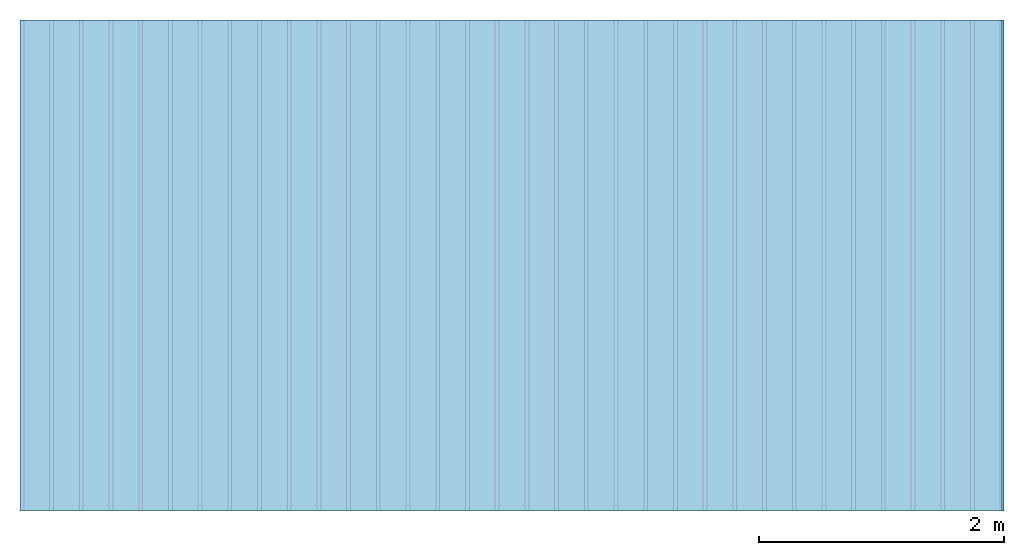
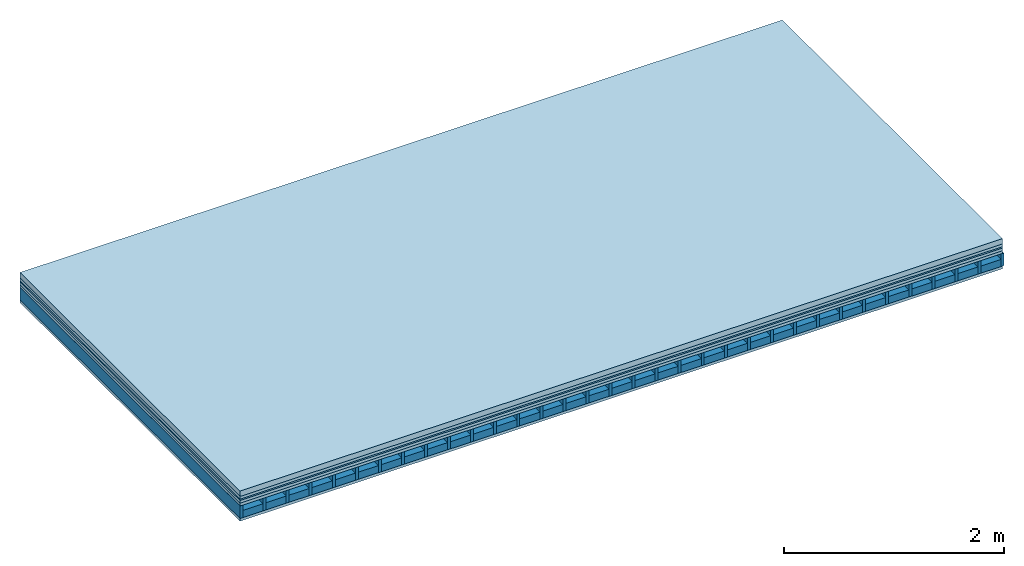
# One storey: 6 plates, 2 members, 1 element without a shape of its own.
"""IFC4 building model written with IfcOpenShell, lengths in metres."""

from ifc_helpers import new_model, si_unit, derived_unit, direction, frame, frame_2d, origin, origin_with_axes, place, context, project, spatial, rectangle, extrude, material, layer, layer_set, type_object, element, aggregate, save


model = new_model("IFC4")

# Units and contexts
plan_context = context("Plan", 3, precision=1e-05, world=origin(), true_north=direction((0.0, 1.0)))
model_context = context("Model", 3, precision=1e-05, world=origin(), true_north=direction((0.0, 1.0)))
ifc_project = project(units=[si_unit("LENGTHUNIT", "METRE"), derived_unit("SOUNDPRESSUREUNIT", [(si_unit("PRESSUREUNIT", "PASCAL", prefix="MICRO"), 0)]), si_unit("ENERGYUNIT", "JOULE", prefix="MEGA"), si_unit("MASSUNIT", "GRAM", prefix="KILO"), derived_unit("THERMALTRANSMITTANCEUNIT", [(si_unit("POWERUNIT", "WATT"), 1), (si_unit("AREAUNIT", "SQUARE_METRE"), -1), (si_unit("THERMODYNAMICTEMPERATUREUNIT", "KELVIN"), -1)]), derived_unit("AREADENSITYUNIT", [(si_unit("MASSUNIT", "GRAM", prefix="KILO"), 1), (si_unit("AREAUNIT", "SQUARE_METRE"), -1)]), derived_unit("USERDEFINED", [(si_unit("ENERGYUNIT", "JOULE", prefix="MEGA"), 1), (si_unit("AREAUNIT", "SQUARE_METRE"), -1)])], contexts=[plan_context, model_context])

# Site, building, storey
site = spatial("IfcSite", under=ifc_project)
building_placement = place(None, origin())
building = spatial("IfcBuilding", under=site, at=building_placement)
storey_placement = place(building_placement, origin())
storey = spatial("IfcBuildingStorey", under=building, at=storey_placement)

# Slab, members, plates
ifc_material_1 = material(Name="Cement screed", Category="04.006")
ifc_layer_1 = layer(ifc_material_1, 0.06, Name="On-material")
ifc_material_2 = material()
ifc_layer_2 = layer(ifc_material_2, 0.03, Name="Impact sound insulation")
ifc_material_3 = material(Name="OSB panel", Category="07.013")
ifc_layer_3 = layer(ifc_material_3, 0.015, Name="Additional insulation")
ifc_material_4 = material(Name="with broken")
ifc_layer_4 = layer(ifc_material_4, 0.03, Name="on Supporting structure")
ifc_material_5 = material(Name="Element above")
ifc_layer_5 = layer(ifc_material_5, 0.0305, Name="Sub-floor")
ifc_material_6 = material(Name="Rigid")
ifc_layer_6 = layer(ifc_material_6, 0.0, Name="Bond")
ifc_layer_7 = layer(None, 0.139, Name="Supporting structure")
ifc_material_7 = material(Name="Rigid, of the art")
ifc_layer_8 = layer(ifc_material_7, 0.0, Name="Bond")
ifc_material_8 = material(Name="Element below")
ifc_layer_9 = layer(ifc_material_8, 0.0305, Name="Lower layer 1")
ifc_layer_set = layer_set([ifc_layer_1, ifc_layer_2, ifc_layer_3, ifc_layer_4, ifc_layer_5, ifc_layer_6, ifc_layer_7, ifc_layer_8, ifc_layer_9])
slab_type = type_object("IfcSlabType", Name="A2279", PredefinedType="NOTDEFINED", material=ifc_layer_set)
slab_placement = place(None, frame((0.0, 0.0, 0.0), z_axis=(0.0, 0.0, -1.0), x_axis=(1.0, 0.0, 0.0)))
slab = element("IfcSlab", 1, at=slab_placement, inside=storey, type_object=slab_type, material=ifc_layer_set, Name="Slab #1")
ifc_material_9 = material(Name="Floor element EB")
member_1_placement = place(slab_placement, origin())
member_1 = element("IfcMember", 2, at=member_1_placement, material=ifc_material_9, Name="Supporting structure", context=plan_context, shape_type="SweptSolid", body=[
    extrude(rectangle(XDim=0.031, YDim=0.139, at=frame_2d((0.0155, 0.0695), x_axis=(1.0, 0.0))), frame((0.0, 4.0, 0.1655), z_axis=(0.0, -1.0, 0.0), x_axis=(1.0, 0.0, 0.0)), (0.0, 0.0, 1.0), 4.0),
    extrude(rectangle(XDim=0.031, YDim=0.139, at=frame_2d((0.0155, 0.0695), x_axis=(1.0, 0.0))), frame((0.242, 4.0, 0.1655), z_axis=(0.0, -1.0, 0.0), x_axis=(1.0, 0.0, 0.0)), (0.0, 0.0, 1.0), 4.0),
    extrude(rectangle(XDim=0.031, YDim=0.139, at=frame_2d((0.0155, 0.0695), x_axis=(1.0, 0.0))), frame((0.484, 4.0, 0.1655), z_axis=(0.0, -1.0, 0.0), x_axis=(1.0, 0.0, 0.0)), (0.0, 0.0, 1.0), 4.0),
    extrude(rectangle(XDim=0.031, YDim=0.139, at=frame_2d((0.0155, 0.0695), x_axis=(1.0, 0.0))), frame((0.726, 4.0, 0.1655), z_axis=(0.0, -1.0, 0.0), x_axis=(1.0, 0.0, 0.0)), (0.0, 0.0, 1.0), 4.0),
    extrude(rectangle(XDim=0.031, YDim=0.139, at=frame_2d((0.0155, 0.0695), x_axis=(1.0, 0.0))), frame((0.968, 4.0, 0.1655), z_axis=(0.0, -1.0, 0.0), x_axis=(1.0, 0.0, 0.0)), (0.0, 0.0, 1.0), 4.0),
    extrude(rectangle(XDim=0.031, YDim=0.139, at=frame_2d((0.0155, 0.0695), x_axis=(1.0, 0.0))), frame((1.21, 4.0, 0.1655), z_axis=(0.0, -1.0, 0.0), x_axis=(1.0, 0.0, 0.0)), (0.0, 0.0, 1.0), 4.0),
    extrude(rectangle(XDim=0.031, YDim=0.139, at=frame_2d((0.0155, 0.0695), x_axis=(1.0, 0.0))), frame((1.452, 4.0, 0.1655), z_axis=(0.0, -1.0, 0.0), x_axis=(1.0, 0.0, 0.0)), (0.0, 0.0, 1.0), 4.0),
    extrude(rectangle(XDim=0.031, YDim=0.139, at=frame_2d((0.0155, 0.0695), x_axis=(1.0, 0.0))), frame((1.694, 4.0, 0.1655), z_axis=(0.0, -1.0, 0.0), x_axis=(1.0, 0.0, 0.0)), (0.0, 0.0, 1.0), 4.0),
    extrude(rectangle(XDim=0.031, YDim=0.139, at=frame_2d((0.0155, 0.0695), x_axis=(1.0, 0.0))), frame((1.936, 4.0, 0.1655), z_axis=(0.0, -1.0, 0.0), x_axis=(1.0, 0.0, 0.0)), (0.0, 0.0, 1.0), 4.0),
    extrude(rectangle(XDim=0.031, YDim=0.139, at=frame_2d((0.0155, 0.0695), x_axis=(1.0, 0.0))), frame((2.178, 4.0, 0.1655), z_axis=(0.0, -1.0, 0.0), x_axis=(1.0, 0.0, 0.0)), (0.0, 0.0, 1.0), 4.0),
    extrude(rectangle(XDim=0.031, YDim=0.139, at=frame_2d((0.0155, 0.0695), x_axis=(1.0, 0.0))), frame((2.42, 4.0, 0.1655), z_axis=(0.0, -1.0, 0.0), x_axis=(1.0, 0.0, 0.0)), (0.0, 0.0, 1.0), 4.0),
    extrude(rectangle(XDim=0.031, YDim=0.139, at=frame_2d((0.0155, 0.0695), x_axis=(1.0, 0.0))), frame((2.662, 4.0, 0.1655), z_axis=(0.0, -1.0, 0.0), x_axis=(1.0, 0.0, 0.0)), (0.0, 0.0, 1.0), 4.0),
    extrude(rectangle(XDim=0.031, YDim=0.139, at=frame_2d((0.0155, 0.0695), x_axis=(1.0, 0.0))), frame((2.904, 4.0, 0.1655), z_axis=(0.0, -1.0, 0.0), x_axis=(1.0, 0.0, 0.0)), (0.0, 0.0, 1.0), 4.0),
    extrude(rectangle(XDim=0.031, YDim=0.139, at=frame_2d((0.0155, 0.0695), x_axis=(1.0, 0.0))), frame((3.146, 4.0, 0.1655), z_axis=(0.0, -1.0, 0.0), x_axis=(1.0, 0.0, 0.0)), (0.0, 0.0, 1.0), 4.0),
    extrude(rectangle(XDim=0.031, YDim=0.139, at=frame_2d((0.0155, 0.0695), x_axis=(1.0, 0.0))), frame((3.388, 4.0, 0.1655), z_axis=(0.0, -1.0, 0.0), x_axis=(1.0, 0.0, 0.0)), (0.0, 0.0, 1.0), 4.0),
    extrude(rectangle(XDim=0.031, YDim=0.139, at=frame_2d((0.0155, 0.0695), x_axis=(1.0, 0.0))), frame((3.63, 4.0, 0.1655), z_axis=(0.0, -1.0, 0.0), x_axis=(1.0, 0.0, 0.0)), (0.0, 0.0, 1.0), 4.0),
    extrude(rectangle(XDim=0.031, YDim=0.139, at=frame_2d((0.0155, 0.0695), x_axis=(1.0, 0.0))), frame((3.872, 4.0, 0.1655), z_axis=(0.0, -1.0, 0.0), x_axis=(1.0, 0.0, 0.0)), (0.0, 0.0, 1.0), 4.0),
    extrude(rectangle(XDim=0.031, YDim=0.139, at=frame_2d((0.0155, 0.0695), x_axis=(1.0, 0.0))), frame((4.114, 4.0, 0.1655), z_axis=(0.0, -1.0, 0.0), x_axis=(1.0, 0.0, 0.0)), (0.0, 0.0, 1.0), 4.0),
    extrude(rectangle(XDim=0.031, YDim=0.139, at=frame_2d((0.0155, 0.0695), x_axis=(1.0, 0.0))), frame((4.356, 4.0, 0.1655), z_axis=(0.0, -1.0, 0.0), x_axis=(1.0, 0.0, 0.0)), (0.0, 0.0, 1.0), 4.0),
    extrude(rectangle(XDim=0.031, YDim=0.139, at=frame_2d((0.0155, 0.0695), x_axis=(1.0, 0.0))), frame((4.598, 4.0, 0.1655), z_axis=(0.0, -1.0, 0.0), x_axis=(1.0, 0.0, 0.0)), (0.0, 0.0, 1.0), 4.0),
    extrude(rectangle(XDim=0.031, YDim=0.139, at=frame_2d((0.0155, 0.0695), x_axis=(1.0, 0.0))), frame((4.84, 4.0, 0.1655), z_axis=(0.0, -1.0, 0.0), x_axis=(1.0, 0.0, 0.0)), (0.0, 0.0, 1.0), 4.0),
    extrude(rectangle(XDim=0.031, YDim=0.139, at=frame_2d((0.0155, 0.0695), x_axis=(1.0, 0.0))), frame((5.082, 4.0, 0.1655), z_axis=(0.0, -1.0, 0.0), x_axis=(1.0, 0.0, 0.0)), (0.0, 0.0, 1.0), 4.0),
    extrude(rectangle(XDim=0.031, YDim=0.139, at=frame_2d((0.0155, 0.0695), x_axis=(1.0, 0.0))), frame((5.324, 4.0, 0.1655), z_axis=(0.0, -1.0, 0.0), x_axis=(1.0, 0.0, 0.0)), (0.0, 0.0, 1.0), 4.0),
    extrude(rectangle(XDim=0.031, YDim=0.139, at=frame_2d((0.0155, 0.0695), x_axis=(1.0, 0.0))), frame((5.566, 4.0, 0.1655), z_axis=(0.0, -1.0, 0.0), x_axis=(1.0, 0.0, 0.0)), (0.0, 0.0, 1.0), 4.0),
    extrude(rectangle(XDim=0.031, YDim=0.139, at=frame_2d((0.0155, 0.0695), x_axis=(1.0, 0.0))), frame((5.808, 4.0, 0.1655), z_axis=(0.0, -1.0, 0.0), x_axis=(1.0, 0.0, 0.0)), (0.0, 0.0, 1.0), 4.0),
    extrude(rectangle(XDim=0.031, YDim=0.139, at=frame_2d((0.0155, 0.0695), x_axis=(1.0, 0.0))), frame((6.05, 4.0, 0.1655), z_axis=(0.0, -1.0, 0.0), x_axis=(1.0, 0.0, 0.0)), (0.0, 0.0, 1.0), 4.0),
    extrude(rectangle(XDim=0.031, YDim=0.139, at=frame_2d((0.0155, 0.0695), x_axis=(1.0, 0.0))), frame((6.292, 4.0, 0.1655), z_axis=(0.0, -1.0, 0.0), x_axis=(1.0, 0.0, 0.0)), (0.0, 0.0, 1.0), 4.0),
    extrude(rectangle(XDim=0.031, YDim=0.139, at=frame_2d((0.0155, 0.0695), x_axis=(1.0, 0.0))), frame((6.534, 4.0, 0.1655), z_axis=(0.0, -1.0, 0.0), x_axis=(1.0, 0.0, 0.0)), (0.0, 0.0, 1.0), 4.0),
    extrude(rectangle(XDim=0.031, YDim=0.139, at=frame_2d((0.0155, 0.0695), x_axis=(1.0, 0.0))), frame((6.776, 4.0, 0.1655), z_axis=(0.0, -1.0, 0.0), x_axis=(1.0, 0.0, 0.0)), (0.0, 0.0, 1.0), 4.0),
    extrude(rectangle(XDim=0.031, YDim=0.139, at=frame_2d((0.0155, 0.0695), x_axis=(1.0, 0.0))), frame((7.018, 4.0, 0.1655), z_axis=(0.0, -1.0, 0.0), x_axis=(1.0, 0.0, 0.0)), (0.0, 0.0, 1.0), 4.0),
    extrude(rectangle(XDim=0.031, YDim=0.139, at=frame_2d((0.0155, 0.0695), x_axis=(1.0, 0.0))), frame((7.26, 4.0, 0.1655), z_axis=(0.0, -1.0, 0.0), x_axis=(1.0, 0.0, 0.0)), (0.0, 0.0, 1.0), 4.0),
    extrude(rectangle(XDim=0.031, YDim=0.139, at=frame_2d((0.0155, 0.0695), x_axis=(1.0, 0.0))), frame((7.502, 4.0, 0.1655), z_axis=(0.0, -1.0, 0.0), x_axis=(1.0, 0.0, 0.0)), (0.0, 0.0, 1.0), 4.0),
    extrude(rectangle(XDim=0.031, YDim=0.139, at=frame_2d((0.0155, 0.0695), x_axis=(1.0, 0.0))), frame((7.744, 4.0, 0.1655), z_axis=(0.0, -1.0, 0.0), x_axis=(1.0, 0.0, 0.0)), (0.0, 0.0, 1.0), 4.0),
    extrude(rectangle(XDim=0.031, YDim=0.139, at=frame_2d((0.0155, 0.0695), x_axis=(1.0, 0.0))), frame((7.986, 4.0, 0.1655), z_axis=(0.0, -1.0, 0.0), x_axis=(1.0, 0.0, 0.0)), (0.0, 0.0, 1.0), 4.0),
])
ifc_material_10 = material(Name="CCN 2-3mm")
member_2_placement = place(slab_placement, origin())
member_2 = element("IfcMember", 3, at=member_2_placement, material=ifc_material_10, Name="in supporting structure", context=plan_context, shape_type="SweptSolid", body=[
    extrude(rectangle(XDim=0.211, YDim=0.0793, at=frame_2d((0.1055, 0.03965), x_axis=(1.0, 0.0))), frame((0.031, 4.0, 0.2252), z_axis=(0.0, -1.0, 0.0), x_axis=(1.0, 0.0, 0.0)), (0.0, 0.0, 1.0), 4.0),
    extrude(rectangle(XDim=0.211, YDim=0.0793, at=frame_2d((0.1055, 0.03965), x_axis=(1.0, 0.0))), frame((0.273, 4.0, 0.2252), z_axis=(0.0, -1.0, 0.0), x_axis=(1.0, 0.0, 0.0)), (0.0, 0.0, 1.0), 4.0),
    extrude(rectangle(XDim=0.211, YDim=0.0793, at=frame_2d((0.1055, 0.03965), x_axis=(1.0, 0.0))), frame((0.515, 4.0, 0.2252), z_axis=(0.0, -1.0, 0.0), x_axis=(1.0, 0.0, 0.0)), (0.0, 0.0, 1.0), 4.0),
    extrude(rectangle(XDim=0.211, YDim=0.0793, at=frame_2d((0.1055, 0.03965), x_axis=(1.0, 0.0))), frame((0.757, 4.0, 0.2252), z_axis=(0.0, -1.0, 0.0), x_axis=(1.0, 0.0, 0.0)), (0.0, 0.0, 1.0), 4.0),
    extrude(rectangle(XDim=0.211, YDim=0.0793, at=frame_2d((0.1055, 0.03965), x_axis=(1.0, 0.0))), frame((0.999, 4.0, 0.2252), z_axis=(0.0, -1.0, 0.0), x_axis=(1.0, 0.0, 0.0)), (0.0, 0.0, 1.0), 4.0),
    extrude(rectangle(XDim=0.211, YDim=0.0793, at=frame_2d((0.1055, 0.03965), x_axis=(1.0, 0.0))), frame((1.241, 4.0, 0.2252), z_axis=(0.0, -1.0, 0.0), x_axis=(1.0, 0.0, 0.0)), (0.0, 0.0, 1.0), 4.0),
    extrude(rectangle(XDim=0.211, YDim=0.0793, at=frame_2d((0.1055, 0.03965), x_axis=(1.0, 0.0))), frame((1.483, 4.0, 0.2252), z_axis=(0.0, -1.0, 0.0), x_axis=(1.0, 0.0, 0.0)), (0.0, 0.0, 1.0), 4.0),
    extrude(rectangle(XDim=0.211, YDim=0.0793, at=frame_2d((0.1055, 0.03965), x_axis=(1.0, 0.0))), frame((1.725, 4.0, 0.2252), z_axis=(0.0, -1.0, 0.0), x_axis=(1.0, 0.0, 0.0)), (0.0, 0.0, 1.0), 4.0),
    extrude(rectangle(XDim=0.211, YDim=0.0793, at=frame_2d((0.1055, 0.03965), x_axis=(1.0, 0.0))), frame((1.967, 4.0, 0.2252), z_axis=(0.0, -1.0, 0.0), x_axis=(1.0, 0.0, 0.0)), (0.0, 0.0, 1.0), 4.0),
    extrude(rectangle(XDim=0.211, YDim=0.0793, at=frame_2d((0.1055, 0.03965), x_axis=(1.0, 0.0))), frame((2.209, 4.0, 0.2252), z_axis=(0.0, -1.0, 0.0), x_axis=(1.0, 0.0, 0.0)), (0.0, 0.0, 1.0), 4.0),
    extrude(rectangle(XDim=0.211, YDim=0.0793, at=frame_2d((0.1055, 0.03965), x_axis=(1.0, 0.0))), frame((2.451, 4.0, 0.2252), z_axis=(0.0, -1.0, 0.0), x_axis=(1.0, 0.0, 0.0)), (0.0, 0.0, 1.0), 4.0),
    extrude(rectangle(XDim=0.211, YDim=0.0793, at=frame_2d((0.1055, 0.03965), x_axis=(1.0, 0.0))), frame((2.693, 4.0, 0.2252), z_axis=(0.0, -1.0, 0.0), x_axis=(1.0, 0.0, 0.0)), (0.0, 0.0, 1.0), 4.0),
    extrude(rectangle(XDim=0.211, YDim=0.0793, at=frame_2d((0.1055, 0.03965), x_axis=(1.0, 0.0))), frame((2.935, 4.0, 0.2252), z_axis=(0.0, -1.0, 0.0), x_axis=(1.0, 0.0, 0.0)), (0.0, 0.0, 1.0), 4.0),
    extrude(rectangle(XDim=0.211, YDim=0.0793, at=frame_2d((0.1055, 0.03965), x_axis=(1.0, 0.0))), frame((3.177, 4.0, 0.2252), z_axis=(0.0, -1.0, 0.0), x_axis=(1.0, 0.0, 0.0)), (0.0, 0.0, 1.0), 4.0),
    extrude(rectangle(XDim=0.211, YDim=0.0793, at=frame_2d((0.1055, 0.03965), x_axis=(1.0, 0.0))), frame((3.419, 4.0, 0.2252), z_axis=(0.0, -1.0, 0.0), x_axis=(1.0, 0.0, 0.0)), (0.0, 0.0, 1.0), 4.0),
    extrude(rectangle(XDim=0.211, YDim=0.0793, at=frame_2d((0.1055, 0.03965), x_axis=(1.0, 0.0))), frame((3.661, 4.0, 0.2252), z_axis=(0.0, -1.0, 0.0), x_axis=(1.0, 0.0, 0.0)), (0.0, 0.0, 1.0), 4.0),
    extrude(rectangle(XDim=0.211, YDim=0.0793, at=frame_2d((0.1055, 0.03965), x_axis=(1.0, 0.0))), frame((3.903, 4.0, 0.2252), z_axis=(0.0, -1.0, 0.0), x_axis=(1.0, 0.0, 0.0)), (0.0, 0.0, 1.0), 4.0),
    extrude(rectangle(XDim=0.211, YDim=0.0793, at=frame_2d((0.1055, 0.03965), x_axis=(1.0, 0.0))), frame((4.145, 4.0, 0.2252), z_axis=(0.0, -1.0, 0.0), x_axis=(1.0, 0.0, 0.0)), (0.0, 0.0, 1.0), 4.0),
    extrude(rectangle(XDim=0.211, YDim=0.0793, at=frame_2d((0.1055, 0.03965), x_axis=(1.0, 0.0))), frame((4.387, 4.0, 0.2252), z_axis=(0.0, -1.0, 0.0), x_axis=(1.0, 0.0, 0.0)), (0.0, 0.0, 1.0), 4.0),
    extrude(rectangle(XDim=0.211, YDim=0.0793, at=frame_2d((0.1055, 0.03965), x_axis=(1.0, 0.0))), frame((4.629, 4.0, 0.2252), z_axis=(0.0, -1.0, 0.0), x_axis=(1.0, 0.0, 0.0)), (0.0, 0.0, 1.0), 4.0),
    extrude(rectangle(XDim=0.211, YDim=0.0793, at=frame_2d((0.1055, 0.03965), x_axis=(1.0, 0.0))), frame((4.871, 4.0, 0.2252), z_axis=(0.0, -1.0, 0.0), x_axis=(1.0, 0.0, 0.0)), (0.0, 0.0, 1.0), 4.0),
    extrude(rectangle(XDim=0.211, YDim=0.0793, at=frame_2d((0.1055, 0.03965), x_axis=(1.0, 0.0))), frame((5.113, 4.0, 0.2252), z_axis=(0.0, -1.0, 0.0), x_axis=(1.0, 0.0, 0.0)), (0.0, 0.0, 1.0), 4.0),
    extrude(rectangle(XDim=0.211, YDim=0.0793, at=frame_2d((0.1055, 0.03965), x_axis=(1.0, 0.0))), frame((5.355, 4.0, 0.2252), z_axis=(0.0, -1.0, 0.0), x_axis=(1.0, 0.0, 0.0)), (0.0, 0.0, 1.0), 4.0),
    extrude(rectangle(XDim=0.211, YDim=0.0793, at=frame_2d((0.1055, 0.03965), x_axis=(1.0, 0.0))), frame((5.597, 4.0, 0.2252), z_axis=(0.0, -1.0, 0.0), x_axis=(1.0, 0.0, 0.0)), (0.0, 0.0, 1.0), 4.0),
    extrude(rectangle(XDim=0.211, YDim=0.0793, at=frame_2d((0.1055, 0.03965), x_axis=(1.0, 0.0))), frame((5.839, 4.0, 0.2252), z_axis=(0.0, -1.0, 0.0), x_axis=(1.0, 0.0, 0.0)), (0.0, 0.0, 1.0), 4.0),
    extrude(rectangle(XDim=0.211, YDim=0.0793, at=frame_2d((0.1055, 0.03965), x_axis=(1.0, 0.0))), frame((6.081, 4.0, 0.2252), z_axis=(0.0, -1.0, 0.0), x_axis=(1.0, 0.0, 0.0)), (0.0, 0.0, 1.0), 4.0),
    extrude(rectangle(XDim=0.211, YDim=0.0793, at=frame_2d((0.1055, 0.03965), x_axis=(1.0, 0.0))), frame((6.323, 4.0, 0.2252), z_axis=(0.0, -1.0, 0.0), x_axis=(1.0, 0.0, 0.0)), (0.0, 0.0, 1.0), 4.0),
    extrude(rectangle(XDim=0.211, YDim=0.0793, at=frame_2d((0.1055, 0.03965), x_axis=(1.0, 0.0))), frame((6.565, 4.0, 0.2252), z_axis=(0.0, -1.0, 0.0), x_axis=(1.0, 0.0, 0.0)), (0.0, 0.0, 1.0), 4.0),
    extrude(rectangle(XDim=0.211, YDim=0.0793, at=frame_2d((0.1055, 0.03965), x_axis=(1.0, 0.0))), frame((6.807, 4.0, 0.2252), z_axis=(0.0, -1.0, 0.0), x_axis=(1.0, 0.0, 0.0)), (0.0, 0.0, 1.0), 4.0),
    extrude(rectangle(XDim=0.211, YDim=0.0793, at=frame_2d((0.1055, 0.03965), x_axis=(1.0, 0.0))), frame((7.049, 4.0, 0.2252), z_axis=(0.0, -1.0, 0.0), x_axis=(1.0, 0.0, 0.0)), (0.0, 0.0, 1.0), 4.0),
    extrude(rectangle(XDim=0.211, YDim=0.0793, at=frame_2d((0.1055, 0.03965), x_axis=(1.0, 0.0))), frame((7.291, 4.0, 0.2252), z_axis=(0.0, -1.0, 0.0), x_axis=(1.0, 0.0, 0.0)), (0.0, 0.0, 1.0), 4.0),
    extrude(rectangle(XDim=0.211, YDim=0.0793, at=frame_2d((0.1055, 0.03965), x_axis=(1.0, 0.0))), frame((7.533, 4.0, 0.2252), z_axis=(0.0, -1.0, 0.0), x_axis=(1.0, 0.0, 0.0)), (0.0, 0.0, 1.0), 4.0),
    extrude(rectangle(XDim=0.211, YDim=0.0793, at=frame_2d((0.1055, 0.03965), x_axis=(1.0, 0.0))), frame((7.775, 4.0, 0.2252), z_axis=(0.0, -1.0, 0.0), x_axis=(1.0, 0.0, 0.0)), (0.0, 0.0, 1.0), 4.0),
])
plate_1_placement = place(slab_placement, origin())
plate_1 = element("IfcPlate", 4, at=plate_1_placement, material=ifc_material_1, Name="On-material", context=plan_context, shape_type="SweptSolid", body=[
    extrude(rectangle(XDim=8.0, YDim=4.0, at=frame_2d((4.0, 2.0), x_axis=(1.0, 0.0))), origin_with_axes(), (0.0, 0.0, 1.0), 0.06),
])
plate_2_placement = place(slab_placement, origin())
plate_2 = element("IfcPlate", 5, at=plate_2_placement, material=ifc_material_2, Name="Impact sound insulation", context=plan_context, shape_type="SweptSolid", body=[
    extrude(rectangle(XDim=8.0, YDim=4.0, at=frame_2d((4.0, 2.0), x_axis=(1.0, 0.0))), frame((0.0, 0.0, 0.06), z_axis=(0.0, 0.0, 1.0), x_axis=(1.0, 0.0, 0.0)), (0.0, 0.0, 1.0), 0.03),
])
plate_3_placement = place(slab_placement, origin())
plate_3 = element("IfcPlate", 6, at=plate_3_placement, material=ifc_material_3, Name="Additional insulation", context=plan_context, shape_type="SweptSolid", body=[
    extrude(rectangle(XDim=8.0, YDim=4.0, at=frame_2d((4.0, 2.0), x_axis=(1.0, 0.0))), frame((0.0, 0.0, 0.09), z_axis=(0.0, 0.0, 1.0), x_axis=(1.0, 0.0, 0.0)), (0.0, 0.0, 1.0), 0.015),
])
plate_4_placement = place(slab_placement, origin())
plate_4 = element("IfcPlate", 7, at=plate_4_placement, material=ifc_material_4, Name="on Supporting structure", context=plan_context, shape_type="SweptSolid", body=[
    extrude(rectangle(XDim=8.0, YDim=4.0, at=frame_2d((4.0, 2.0), x_axis=(1.0, 0.0))), frame((0.0, 0.0, 0.105), z_axis=(0.0, 0.0, 1.0), x_axis=(1.0, 0.0, 0.0)), (0.0, 0.0, 1.0), 0.03),
])
plate_5_placement = place(slab_placement, origin())
plate_5 = element("IfcPlate", 8, at=plate_5_placement, material=ifc_material_5, Name="Sub-floor", context=plan_context, shape_type="SweptSolid", body=[
    extrude(rectangle(XDim=8.0, YDim=4.0, at=frame_2d((4.0, 2.0), x_axis=(1.0, 0.0))), frame((0.0, 0.0, 0.135), z_axis=(0.0, 0.0, 1.0), x_axis=(1.0, 0.0, 0.0)), (0.0, 0.0, 1.0), 0.0305),
])
plate_6_placement = place(slab_placement, origin())
plate_6 = element("IfcPlate", 9, at=plate_6_placement, material=ifc_material_8, Name="Lower layer 1", context=plan_context, shape_type="SweptSolid", body=[
    extrude(rectangle(XDim=8.0, YDim=4.0, at=frame_2d((4.0, 2.0), x_axis=(1.0, 0.0))), frame((0.0, 0.0, 0.3045), z_axis=(0.0, 0.0, 1.0), x_axis=(1.0, 0.0, 0.0)), (0.0, 0.0, 1.0), 0.0305),
])
aggregate(slab, [plate_1, plate_2, plate_3, plate_4, plate_5, member_1, member_2, plate_6])

save(model, "model.ifc")
